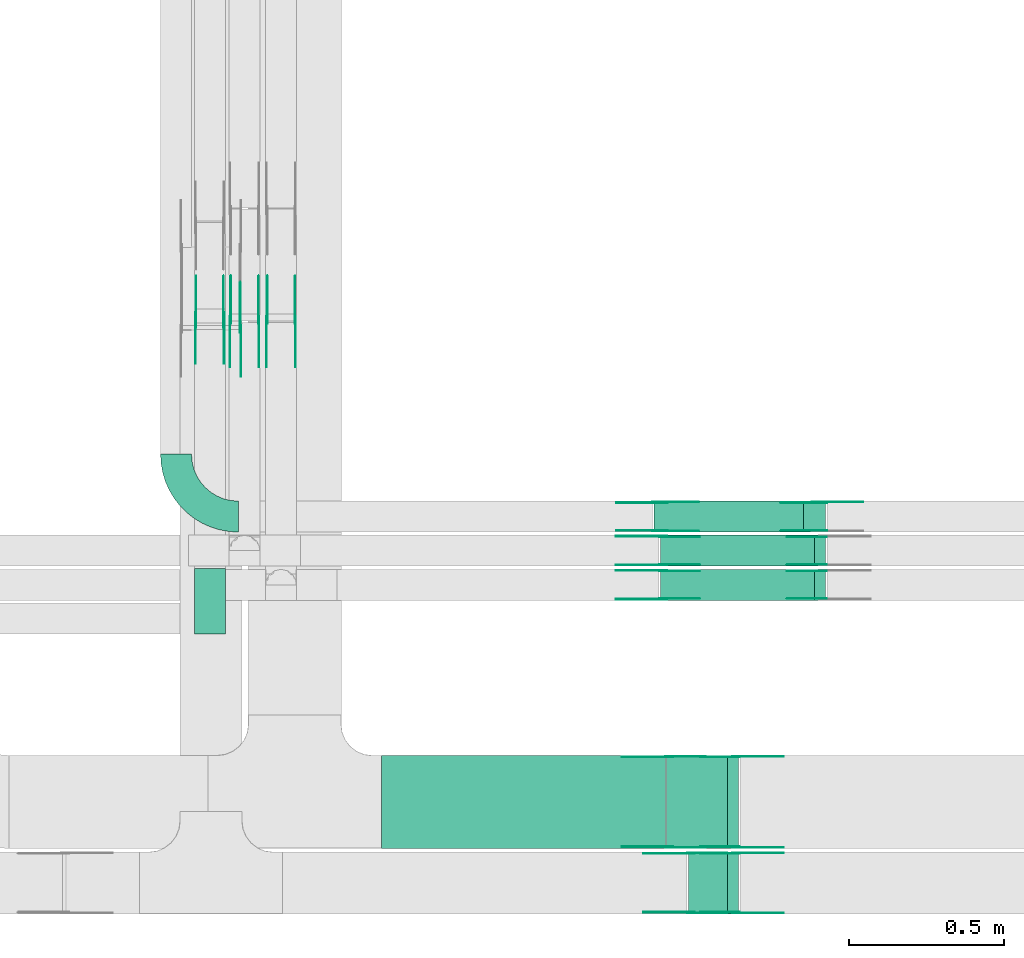
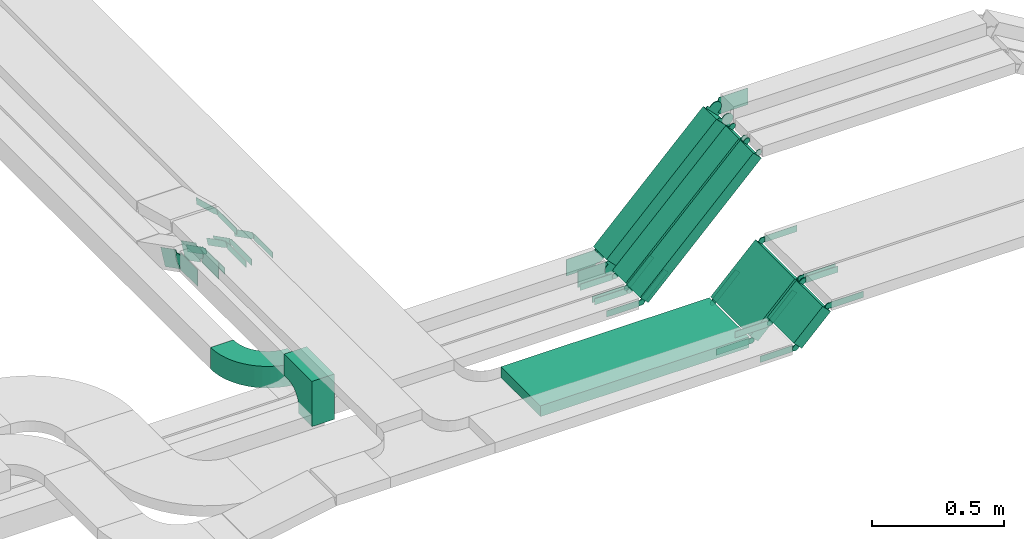
# One storey, part 16 of 19: 51 flow fittings, 6 flow segments.
"""IFC2X3 building model written with IfcOpenShell, lengths in millimetres."""

import ifcopenshell
import ifcopenshell.guid

model = None  # the IFC model being written
_history = None  # IfcOwnerHistory: only IFC2X3 demands one
_inside = {}  # id of a spatial element -> (the spatial element, [elements in it])
_under = {}  # id of a project, library or spatial element -> (it, [spatial elements below it])
_declared = {}  # id of a project -> (the project, [libraries it declares])
_typed = {}  # id of a type object -> (the type object, [elements of that type])
_made_of = {}  # id of a material, layer set ... -> (it, [elements and type objects made of it])


def new_model(schema):
    """Start an empty IFC model of exactly this schema.

    Asked for "IFC4X3", IfcOpenShell would pick the latest addendum, in which some entities
    have other attributes; the version numbers below select the first issue.
    IFC2X3 requires an IfcOwnerHistory on every rooted entity: one is made here for all.
    """
    global model, _history
    if schema == "IFC4X3":
        model = ifcopenshell.file(schema_version=(4, 3, 0, 0))
    else:
        model = ifcopenshell.file(schema=schema)
    _inside.clear()
    _under.clear()
    _declared.clear()
    _typed.clear()
    _made_of.clear()
    _history = None
    if model.schema == "IFC2X3":
        org = make("IfcOrganization", Name="unknown")
        user = make(
            "IfcPersonAndOrganization",
            ThePerson=make("IfcPerson", FamilyName="unknown"),
            TheOrganization=org,
        )
        app = make(
            "IfcApplication",
            ApplicationDeveloper=org,
            Version="unknown",
            ApplicationFullName="unknown",
            ApplicationIdentifier="unknown",
        )
        _history = make(
            "IfcOwnerHistory",
            OwningUser=user,
            OwningApplication=app,
            ChangeAction="ADDED",
            CreationDate=0,
        )
    return model


def make(cls, **values):
    """One entity of the class cls with the attributes given. An attribute that is None is left unset."""
    return model.create_entity(
        cls, **{name: value for name, value in values.items() if value is not None}
    )


def entity(cls, *values):
    """Any entity or typed value of the class cls, its attributes in the order of the schema. None: left unset."""
    e = model.create_entity(cls)
    for i, value in enumerate(values):
        if value is not None:
            e[i] = value
    return e


def rooted(cls, **values):
    """An entity with a GlobalId (a new one), such as an element, a storey or a relation."""
    return make(cls, GlobalId=ifcopenshell.guid.new(), OwnerHistory=_history, **values)


def si_unit(unit_type, name, prefix=None):
    """IfcSIUnit, for example si_unit("LENGTHUNIT", "METRE", prefix="MILLI")."""
    return make("IfcSIUnit", UnitType=unit_type, Prefix=prefix, Name=name)


def converted_unit(unit_type, name, factor, base, dimensions=None, offset=None):
    """IfcConversionBasedUnit, such as the inch: factor (a typed value) times the base unit."""
    return make(
        "IfcConversionBasedUnit"
        if offset is None
        else "IfcConversionBasedUnitWithOffset",
        ConversionOffset=offset,
        Dimensions=None
        if dimensions is None
        else entity("IfcDimensionalExponents", *dimensions),
        UnitType=unit_type,
        Name=name,
        ConversionFactor=make(
            "IfcMeasureWithUnit", ValueComponent=factor, UnitComponent=base
        ),
    )


def derived_unit(unit_type, elements):
    """IfcDerivedUnit: a product of units, each with its exponent."""
    return make(
        "IfcDerivedUnit",
        Elements=[
            make("IfcDerivedUnitElement", Unit=unit, Exponent=power)
            for unit, power in elements
        ],
        UnitType=unit_type,
    )


def assignment(units):
    """IfcUnitAssignment: the units of a project."""
    return None if units is None else make("IfcUnitAssignment", Units=units)


def point(xyz):
    """IfcCartesianPoint."""
    return None if xyz is None else make("IfcCartesianPoint", Coordinates=xyz)


def direction(xyz):
    """IfcDirection."""
    return None if xyz is None else make("IfcDirection", DirectionRatios=xyz)


def frame(location, z_axis=None, x_axis=None):
    """IfcAxis2Placement3D, a coordinate frame: its origin and axes. An axis left out is left unset."""
    return make(
        "IfcAxis2Placement3D",
        Location=point(location),
        Axis=direction(z_axis),
        RefDirection=direction(x_axis),
    )


def frame_2d(location, x_axis=None):
    """IfcAxis2Placement2D, a coordinate frame in the plane: its origin and x axis."""
    return make(
        "IfcAxis2Placement2D", Location=point(location), RefDirection=direction(x_axis)
    )


def origin():
    """The frame at (0, 0, 0) with its axes left unset."""
    return frame((0.0, 0.0, 0.0))


def origin_2d_with_axis():
    """The frame at (0, 0) in the plane with the x axis (1, 0) written out."""
    return frame_2d((0.0, 0.0), x_axis=(1.0, 0.0))


def place(relative_to, where):
    """IfcLocalPlacement: puts the frame where relative to a parent placement (None: the world)."""
    return make(
        "IfcLocalPlacement", PlacementRelTo=relative_to, RelativePlacement=where
    )


def context(
    kind, dimensions, precision=None, world=None, true_north=None, identifier=None
):
    """IfcGeometricRepresentationContext, for example the 3D "Model" context."""
    return make(
        "IfcGeometricRepresentationContext",
        ContextIdentifier=identifier,
        ContextType=kind,
        CoordinateSpaceDimension=dimensions,
        Precision=precision,
        WorldCoordinateSystem=world,
        TrueNorth=true_north,
    )


def subcontext(parent, identifier, kind, view, scale=None):
    """IfcGeometricRepresentationSubContext, for example "Body" below "Model"."""
    return make(
        "IfcGeometricRepresentationSubContext",
        ContextIdentifier=identifier,
        ContextType=kind,
        ParentContext=parent,
        TargetScale=scale,
        TargetView=view,
    )


def project(units=None, contexts=None):
    """IfcProject with its units and contexts."""
    return rooted(
        "IfcProject",
        Name="project",
        RepresentationContexts=contexts,
        UnitsInContext=assignment(units),
    )


def spatial(cls, under=None, at=None, **own):
    """A site, building, storey or space (cls), placed at a placement, below another one or the project."""
    s = rooted(cls, ObjectPlacement=at, **own)
    if under is not None:
        _under.setdefault(under.id(), (under, []))[1].append(s)
    return s


def polyline(points):
    """IfcPolyline through the points."""
    return make("IfcPolyline", Points=[point(p) for p in points])


def circle_curve(where, radius):
    """IfcCircle in the frame where."""
    return make("IfcCircle", Position=where, Radius=radius)


def parameter(value):
    """IfcParameterValue: where a trimmed curve begins or ends, as a parameter of its basis curve."""
    return model.create_entity("IfcParameterValue", value)


def trimmed(basis, trim1, trim2, sense, master):
    """IfcTrimmedCurve: the piece of a basis curve between two trims."""
    return make(
        "IfcTrimmedCurve",
        BasisCurve=basis,
        Trim1=trim1,
        Trim2=trim2,
        SenseAgreement=sense,
        MasterRepresentation=master,
    )


def segment(curve, same_sense, transition):
    """IfcCompositeCurveSegment."""
    return make(
        "IfcCompositeCurveSegment",
        Transition=transition,
        SameSense=same_sense,
        ParentCurve=curve,
    )


def composite_curve(segments, self_intersect=None):
    """IfcCompositeCurve: segments joined end to end."""
    return make("IfcCompositeCurve", Segments=segments, SelfIntersect=self_intersect)


def profile(cls, at=None, kind="AREA", **sizes):
    """A parametric profile (cls). Its sizes go by their IFC names, for example OverallWidth=200.0."""
    return make(cls, ProfileType=kind, Position=at, **sizes)


def rectangle(**sizes):
    """IfcRectangleProfileDef."""
    return profile("IfcRectangleProfileDef", **sizes)


def outline(outer, holes=None, kind="AREA"):
    """IfcArbitraryClosedProfileDef: a profile drawn as a closed curve; with holes, ...WithVoids."""
    if holes is None:
        return make("IfcArbitraryClosedProfileDef", ProfileType=kind, OuterCurve=outer)
    return make(
        "IfcArbitraryProfileDefWithVoids",
        ProfileType=kind,
        OuterCurve=outer,
        InnerCurves=holes,
    )


def extrude(swept, where, along, depth):
    """IfcExtrudedAreaSolid: the profile swept, set in the frame where, extruded along a direction by depth."""
    return make(
        "IfcExtrudedAreaSolid",
        SweptArea=swept,
        Position=where,
        ExtrudedDirection=direction(along),
        Depth=depth,
    )


def shape(context_of_items, identifier, shape_type, items):
    """IfcShapeRepresentation: the items that make up one representation, for example the "Body"."""
    return make(
        "IfcShapeRepresentation",
        ContextOfItems=context_of_items,
        RepresentationIdentifier=identifier,
        RepresentationType=shape_type,
        Items=items,
    )


def source(mapping_origin, context_of_items, identifier, shape_type, items):
    """IfcRepresentationMap: a shape defined once, which mapped items show again and again."""
    return make(
        "IfcRepresentationMap",
        MappingOrigin=mapping_origin,
        MappedRepresentation=shape(context_of_items, identifier, shape_type, items),
    )


def transform(
    local_origin,
    x_axis=None,
    y_axis=None,
    z_axis=None,
    scale=None,
    scale2=None,
    scale3=None,
    uniform=True,
):
    """IfcCartesianTransformationOperator3D, or its non-uniform kind. x_axis, y_axis, z_axis: its Axis1, 2, 3."""
    if uniform:
        return make(
            "IfcCartesianTransformationOperator3D",
            Axis1=direction(x_axis),
            Axis2=direction(y_axis),
            LocalOrigin=point(local_origin),
            Scale=scale,
            Axis3=direction(z_axis),
        )
    return make(
        "IfcCartesianTransformationOperator3DnonUniform",
        Axis1=direction(x_axis),
        Axis2=direction(y_axis),
        LocalOrigin=point(local_origin),
        Scale=scale,
        Axis3=direction(z_axis),
        Scale2=scale2,
        Scale3=scale3,
    )


def mapped(mapping_source, mapping_target):
    """IfcMappedItem: shows the shape of a source again, moved by a transform."""
    return make(
        "IfcMappedItem", MappingSource=mapping_source, MappingTarget=mapping_target
    )


def material(Name=None, Category=None):
    """IfcMaterial."""
    return make("IfcMaterial", Name=Name, Category=Category)


def made_of(thing, what):
    """Note that an element or type object is made of a material, layer set ...; save() writes the relation."""
    if what is not None:
        _made_of.setdefault(what.id(), (what, []))[1].append(thing)
    return thing


def type_object(cls, material=None, **own):
    """A type object (cls), such as IfcWallType, which elements share."""
    return made_of(rooted(cls, **own), material)


def type_shapes(of_type, sources):
    """Give a type object the sources (RepresentationMaps) that its elements show as mapped items."""
    of_type.RepresentationMaps = sources


def element(
    cls,
    number,
    at=None,
    inside=None,
    cuts=None,
    type_object=None,
    material=None,
    context=None,
    identifier="Body",
    shape_type=None,
    held_by="IfcProductDefinitionShape",
    body=None,
    shapes=None,
    **own,
):
    """One element of the class cls, such as IfcWall. Its Tag is "e" and its number.

    at: its placement. inside: the storey or other place that contains it. cuts: it is an
    opening in that element (IfcRelVoidsElement). A single representation is given by context,
    identifier, shape_type and body (its items); several are given by shapes. held_by: the class
    of the entity that holds the representations. save() writes the other relations.
    """
    e = rooted(cls, Tag="e%d" % number, ObjectPlacement=at, **own)
    if body is not None:
        shapes = [shape(context, identifier, shape_type, body)]
    if shapes is not None:
        e.Representation = make(held_by, Representations=shapes)
    if inside is not None:
        _inside.setdefault(inside.id(), (inside, []))[1].append(e)
    if cuts is not None:
        rooted(
            "IfcRelVoidsElement", RelatingBuildingElement=cuts, RelatedOpeningElement=e
        )
    if type_object is not None:
        _typed.setdefault(type_object.id(), (type_object, []))[1].append(e)
    return made_of(e, material)


def aggregate(whole, parts):
    """IfcRelAggregates: a whole, such as a stair, and the parts it consists of."""
    return rooted("IfcRelAggregates", RelatingObject=whole, RelatedObjects=parts)


def save(model, path):
    """Write the relations noted so far, then the file.

    IfcRelAggregates (storeys below a building ...), IfcRelContainedInSpatialStructure (elements
    in a storey), IfcRelDefinesByType, IfcRelAssociatesMaterial and IfcRelDeclares: one each for
    every whole, place, type object, material and project.
    """
    for whole, parts in _under.values():
        aggregate(whole, parts)
    for where, things in _inside.values():
        rooted(
            "IfcRelContainedInSpatialStructure",
            RelatedElements=things,
            RelatingStructure=where,
        )
    for kind, things in _typed.values():
        rooted("IfcRelDefinesByType", RelatedObjects=things, RelatingType=kind)
    for what, things in _made_of.values():
        rooted("IfcRelAssociatesMaterial", RelatedObjects=things, RelatingMaterial=what)
    for by, libraries in _declared.values():
        rooted("IfcRelDeclares", RelatingContext=by, RelatedDefinitions=libraries)
    model.write(path)


model = new_model("IFC2X3")

# Units and contexts
model_context = context("Model", 3, precision=0.01, world=origin(), true_north=direction((6.12303176911189e-17, 1.0)))
body_context = subcontext(model_context, "Body", "Model", "MODEL_VIEW")
ifc_project = project(units=[si_unit("LENGTHUNIT", "METRE", prefix="MILLI"), si_unit("AREAUNIT", "SQUARE_METRE"), si_unit("VOLUMEUNIT", "CUBIC_METRE"), converted_unit("PLANEANGLEUNIT", "DEGREE", entity("IfcRatioMeasure", 0.0174532925199433), si_unit("PLANEANGLEUNIT", "RADIAN"), dimensions=[0, 0, 0, 0, 0, 0, 0]), si_unit("MASSUNIT", "GRAM", prefix="KILO"), derived_unit("MASSDENSITYUNIT", [(si_unit("MASSUNIT", "GRAM", prefix="KILO"), 1), (si_unit("LENGTHUNIT", "METRE"), -3)]), derived_unit("MOMENTOFINERTIAUNIT", [(si_unit("LENGTHUNIT", "METRE"), 4)]), si_unit("TIMEUNIT", "SECOND"), si_unit("FREQUENCYUNIT", "HERTZ"), si_unit("THERMODYNAMICTEMPERATUREUNIT", "DEGREE_CELSIUS"), derived_unit("THERMALTRANSMITTANCEUNIT", [(si_unit("MASSUNIT", "GRAM", prefix="KILO"), 1), (si_unit("THERMODYNAMICTEMPERATUREUNIT", "KELVIN"), -1), (si_unit("TIMEUNIT", "SECOND"), -3)]), derived_unit("VOLUMETRICFLOWRATEUNIT", [(si_unit("LENGTHUNIT", "METRE"), 3), (si_unit("TIMEUNIT", "SECOND"), -1)]), derived_unit("MASSFLOWRATEUNIT", [(si_unit("MASSUNIT", "GRAM", prefix="KILO"), 1), (si_unit("TIMEUNIT", "SECOND"), -1)]), derived_unit("ROTATIONALFREQUENCYUNIT", [(si_unit("TIMEUNIT", "SECOND"), -1)]), si_unit("ELECTRICCURRENTUNIT", "AMPERE"), si_unit("ELECTRICVOLTAGEUNIT", "VOLT"), si_unit("POWERUNIT", "WATT"), si_unit("FORCEUNIT", "NEWTON", prefix="KILO"), si_unit("ILLUMINANCEUNIT", "LUX"), si_unit("LUMINOUSFLUXUNIT", "LUMEN"), si_unit("LUMINOUSINTENSITYUNIT", "CANDELA"), derived_unit("USERDEFINED", [(si_unit("MASSUNIT", "GRAM", prefix="KILO"), -1), (si_unit("LENGTHUNIT", "METRE"), -2), (si_unit("TIMEUNIT", "SECOND"), 3), (si_unit("LUMINOUSFLUXUNIT", "LUMEN"), 1)]), derived_unit("LINEARVELOCITYUNIT", [(si_unit("LENGTHUNIT", "METRE"), 1), (si_unit("TIMEUNIT", "SECOND"), -1)]), si_unit("PRESSUREUNIT", "PASCAL"), derived_unit("USERDEFINED", [(si_unit("LENGTHUNIT", "METRE"), -2), (si_unit("MASSUNIT", "GRAM", prefix="KILO"), 1), (si_unit("TIMEUNIT", "SECOND"), -2)]), derived_unit("LINEARFORCEUNIT", [(si_unit("MASSUNIT", "GRAM", prefix="KILO"), 1), (si_unit("LENGTHUNIT", "METRE"), 1), (si_unit("TIMEUNIT", "SECOND"), -2), (si_unit("LENGTHUNIT", "METRE"), -1)]), derived_unit("PLANARFORCEUNIT", [(si_unit("MASSUNIT", "GRAM", prefix="KILO"), 1), (si_unit("LENGTHUNIT", "METRE"), 1), (si_unit("TIMEUNIT", "SECOND"), -2), (si_unit("LENGTHUNIT", "METRE"), -2)])], contexts=[model_context])

# Site, building, storey
site_placement = place(None, origin())
site = spatial("IfcSite", under=ifc_project, at=site_placement, CompositionType="ELEMENT")
building_placement = place(site_placement, origin())
building = spatial("IfcBuilding", under=site, at=building_placement, CompositionType="ELEMENT")
storey_placement = place(building_placement, frame((0.0, 0.0, 12000.0)))
storey = spatial("IfcBuildingStorey", under=building, at=storey_placement, CompositionType="ELEMENT", Elevation=12000.0)

# Flow segments
cable_carrier_segment_type = type_object("IfcCableCarrierSegmentType", PredefinedType="CABLETRAYSEGMENT")
flow_segment_1_placement = place(storey_placement, frame((61621.17, 9844.99, 2531.17)))
element("IfcFlowSegment", 1, at=flow_segment_1_placement, inside=storey, type_object=cable_carrier_segment_type, context=body_context, shape_type="SweptSolid", body=[
    extrude(rectangle(XDim=99.999999999999, YDim=99.9999999999989, at=frame_2d((0.0, 0.0), x_axis=(0.0, 1.0))), frame((35.36, 50.0, 35.36), z_axis=(0.707106781186526, 0.0, 0.707106781186569), x_axis=(0.0, 1.0, 0.0)), (0.0, 0.0, 1.0), 681.584919885831),
])
for number, where in (
    (2, (61641.88, 9734.99, 2516.52)),
    (3, (61641.88, 9624.99, 2516.52)),
):
    element("IfcFlowSegment", number, at=place(storey_placement, frame(where)), inside=storey, type_object=cable_carrier_segment_type, context=body_context, shape_type="SweptSolid", body=[
        extrude(rectangle(XDim=49.9999999999895, YDim=99.9999999999989, at=frame_2d((0.0, 0.0), x_axis=(0.0, 1.0))), frame((17.68, 50.0, 17.68), z_axis=(0.707106781186548, 0.0, 0.707106781186548), x_axis=(0.0, 1.0, 0.0)), (0.0, 0.0, 1.0), 702.295598004474),
    ])
flow_segment_2_placement = place(storey_placement, frame((60742.55, 8824.99, 2800.0)))
element("IfcFlowSegment", 4, at=flow_segment_2_placement, inside=storey, type_object=cable_carrier_segment_type, context=body_context, shape_type="SweptSolid", body=[
    extrude(rectangle(XDim=914.543199050556, YDim=299.999999999999, at=origin_2d_with_axis()), frame((457.27, 150.0, 0.0)), (0.0, 0.0, 1.0), 50.0000000000016),
])
flow_segment_3_placement = place(storey_placement, frame((61661.63, 8824.99, 2816.52)))
element("IfcFlowSegment", 5, at=flow_segment_3_placement, inside=storey, type_object=cable_carrier_segment_type, context=body_context, shape_type="SweptSolid", body=[
    extrude(rectangle(XDim=278.03152929262, YDim=50.000000000011, at=origin_2d_with_axis()), frame((115.98, 0.0, 115.98), z_axis=(0.0, 1.0, 0.0), x_axis=(0.70710678118652, 0.0, 0.707106781186575)), (0.0, 0.0, 1.0), 299.999999999999),
])
flow_segment_4_placement = place(storey_placement, frame((61731.63, 8613.82, 2886.52)))
element("IfcFlowSegment", 6, at=flow_segment_4_placement, inside=storey, type_object=cable_carrier_segment_type, context=body_context, shape_type="SweptSolid", body=[
    extrude(rectangle(XDim=179.030212681478, YDim=50.0000000000033, at=origin_2d_with_axis()), frame((80.97, 0.0, 80.97), z_axis=(0.0, 1.0, 0.0), x_axis=(0.707106781186414, 0.0, 0.707106781186681)), (0.0, 0.0, 1.0), 200.0),
])

# Flow fittings
ifc_material_1 = material()
cable_carrier_fitting_type_1 = type_object("IfcCableCarrierFittingType", Name="470_DKC_S5_CDV 90 external vertical angle:-", PredefinedType="NOTDEFINED", material=ifc_material_1)
shared_shape_1 = source(origin(), body_context, "Body", "SweptSolid", [
    extrude(outline(composite_curve([segment(polyline([(65.71, 14.29), (95.71, 14.29)]), True, "CONTINUOUS"), segment(polyline([(95.71, 14.29), (95.71, 114.29)]), True, "CONTINUOUS"), segment(polyline([(95.71, 114.29), (-114.29, 114.29)]), True, "CONTINUOUS"), segment(polyline([(-114.29, 114.29), (-114.29, -95.71)]), True, "CONTINUOUS"), segment(polyline([(-114.29, -95.71), (-14.29, -95.71)]), True, "CONTINUOUS"), segment(polyline([(-14.29, -95.71), (-14.29, -65.71)]), True, "CONTINUOUS"), segment(trimmed(circle_curve(frame_2d((65.71, -65.71), x_axis=(-1.0, 0.0)), 80.0), [parameter(270.0)], [parameter(2.54444374517082e-13)], True, "PARAMETER"), False, "CONTINUOUS")], self_intersect=False)), frame((-64.29, 64.29, -49.0), z_axis=(0.0, 0.0, 1.0), x_axis=(-1.0, 0.0, 0.0)), (0.0, 0.0, 1.0), 99.0000000000002),
])
type_shapes(cable_carrier_fitting_type_1, [shared_shape_1])
flow_fitting_1_placement = place(storey_placement, frame((60188.97, 9567.13, 2705.0), z_axis=(1.0, 0.0, 0.0), x_axis=(0.0, -1.0, 0.0)))
element("IfcFlowFitting", 7, at=flow_fitting_1_placement, inside=storey, type_object=cable_carrier_fitting_type_1, material=ifc_material_1, Name="470_DKC_S5_90 external vertical angle", ObjectType="470_DKC_S5_CDV 90 external vertical angle:-", context=body_context, shape_type="MappedRepresentation", body=[
    mapped(shared_shape_1, transform((0.0, 0.0, 0.0), scale=1.0)),
])
ifc_material_2 = material(Name="G")
cable_carrier_fitting_type_2 = type_object("IfcCableCarrierFittingType", PredefinedType="NOTDEFINED", material=ifc_material_2)
shared_shape_2 = source(origin(), body_context, "Body", "SweptSolid", [
    extrude(outline(composite_curve([segment(trimmed(circle_curve(frame_2d((-44.59, 0.0), x_axis=(1.0, 0.0)), 12.5), [parameter(90.0000000000007)], [parameter(270.0)], True, "PARAMETER"), True, "CONTINUOUS"), segment(polyline([(-44.59, -12.5), (-33.09, -12.5)]), True, "CONTINUOUS"), segment(polyline([(-33.09, -12.5), (-31.23, -14.5)]), True, "CONTINUOUS"), segment(polyline([(-31.23, -14.5), (108.91, -14.5)]), True, "CONTINUOUS"), segment(polyline([(108.91, -14.5), (108.91, 14.5)]), True, "CONTINUOUS"), segment(polyline([(108.91, 14.5), (-31.23, 14.5)]), True, "CONTINUOUS"), segment(polyline([(-31.23, 14.5), (-33.09, 12.5)]), True, "CONTINUOUS"), segment(polyline([(-33.09, 12.5), (-44.59, 12.5)]), True, "CONTINUOUS")], self_intersect=False)), frame((44.59, 0.0, 0.0), z_axis=(0.0, 0.0, -1.0), x_axis=(1.0, 0.0, 0.0)), (0.0, 0.0, -1.0), 2.0),
])
type_shapes(cable_carrier_fitting_type_2, [shared_shape_2])
for number, where, z_axis, x_axis in (
    (8, (60288.01, 10499.75, 2895.0), (1.0, 0.0, 0.0), (0.0, -1.0, 0.0)),
    (9, (61650.35, 9830.45, 2525.0), (0.0, 1.0, 0.0), (-1.0, 0.0, 0.0)),
):
    element("IfcFlowFitting", number, at=place(storey_placement, frame(where, z_axis=z_axis, x_axis=x_axis)), inside=storey, type_object=cable_carrier_fitting_type_2, material=ifc_material_2, context=body_context, shape_type="MappedRepresentation", body=[
        mapped(shared_shape_2, transform((0.0, 0.0, 0.0), scale=1.0)),
    ])
cable_carrier_fitting_type_3 = type_object("IfcCableCarrierFittingType", PredefinedType="NOTDEFINED", material=ifc_material_2)
type_shapes(cable_carrier_fitting_type_3, [shared_shape_2])
flow_fitting_2_placement = place(storey_placement, frame((61650.35, 9741.53, 2525.0), z_axis=(0.0, -1.0, 0.0), x_axis=(0.707106781186565, 0.0, 0.70710678118653)))
element("IfcFlowFitting", 10, at=flow_fitting_2_placement, inside=storey, type_object=cable_carrier_fitting_type_3, material=ifc_material_2, context=body_context, shape_type="MappedRepresentation", body=[
    mapped(shared_shape_2, transform((0.0, 0.0, 0.0), scale=1.0)),
])
flow_fitting_3_placement = place(storey_placement, frame((61650.35, 9720.45, 2525.0), z_axis=(0.0, 1.0, 0.0), x_axis=(-1.0, 0.0, 0.0)))
element("IfcFlowFitting", 11, at=flow_fitting_3_placement, inside=storey, type_object=cable_carrier_fitting_type_2, material=ifc_material_2, context=body_context, shape_type="MappedRepresentation", body=[
    mapped(shared_shape_2, transform((0.0, 0.0, 0.0), scale=1.0)),
])
flow_fitting_4_placement = place(storey_placement, frame((61650.35, 9631.53, 2525.0), z_axis=(0.0, -1.0, 0.0), x_axis=(0.70710678118656, 0.0, 0.707106781186535)))
element("IfcFlowFitting", 12, at=flow_fitting_4_placement, inside=storey, type_object=cable_carrier_fitting_type_3, material=ifc_material_2, context=body_context, shape_type="MappedRepresentation", body=[
    mapped(shared_shape_2, transform((0.0, 0.0, 0.0), scale=1.0)),
])
flow_fitting_5_placement = place(storey_placement, frame((61670.11, 8829.53, 2825.0), z_axis=(0.0, -1.0, 0.0), x_axis=(0.707106781186591, 0.0, 0.707106781186504)))
element("IfcFlowFitting", 13, at=flow_fitting_5_placement, inside=storey, type_object=cable_carrier_fitting_type_2, material=ifc_material_2, context=body_context, shape_type="MappedRepresentation", body=[
    mapped(shared_shape_2, transform((0.0, 0.0, 0.0), scale=1.0)),
])
flow_fitting_6_placement = place(storey_placement, frame((61670.11, 9118.45, 2825.0), z_axis=(0.0, 1.0, 0.0), x_axis=(-1.0, 0.0, 0.0)))
element("IfcFlowFitting", 14, at=flow_fitting_6_placement, inside=storey, type_object=cable_carrier_fitting_type_3, material=ifc_material_2, context=body_context, shape_type="MappedRepresentation", body=[
    mapped(shared_shape_2, transform((0.0, 0.0, 0.0), scale=1.0)),
])
flow_fitting_7_placement = place(storey_placement, frame((61740.11, 8618.36, 2895.0), z_axis=(0.0, -1.0, 0.0), x_axis=(0.707106781186497, 0.0, 0.707106781186598)))
element("IfcFlowFitting", 15, at=flow_fitting_7_placement, inside=storey, type_object=cable_carrier_fitting_type_2, material=ifc_material_2, context=body_context, shape_type="MappedRepresentation", body=[
    mapped(shared_shape_2, transform((0.0, 0.0, 0.0), scale=1.0)),
])
for number, where, z_axis, x_axis in (
    (16, (61740.11, 8807.28, 2895.0), (0.0, 1.0, 0.0), (-1.0, 0.0, 0.0)),
    (17, (62165.35, 9741.53, 3040.0), (0.0, -1.0, 0.0), (-0.70710678118656, 0.0, -0.707106781186535)),
):
    element("IfcFlowFitting", number, at=place(storey_placement, frame(where, z_axis=z_axis, x_axis=x_axis)), inside=storey, type_object=cable_carrier_fitting_type_3, material=ifc_material_2, context=body_context, shape_type="MappedRepresentation", body=[
        mapped(shared_shape_2, transform((0.0, 0.0, 0.0), scale=1.0)),
    ])
flow_fitting_8_placement = place(storey_placement, frame((61885.11, 9120.45, 3040.0), z_axis=(0.0, 1.0, 0.0), x_axis=(1.0, 0.0, 0.0)))
element("IfcFlowFitting", 18, at=flow_fitting_8_placement, inside=storey, type_object=cable_carrier_fitting_type_2, material=ifc_material_2, context=body_context, shape_type="MappedRepresentation", body=[
    mapped(shared_shape_2, transform((0.0, 0.0, 0.0), scale=1.0)),
])
flow_fitting_9_placement = place(storey_placement, frame((61885.11, 8831.53, 3040.0), z_axis=(0.0, -1.0, 0.0), x_axis=(-0.707106781186608, 0.0, -0.707106781186487)))
element("IfcFlowFitting", 19, at=flow_fitting_9_placement, inside=storey, type_object=cable_carrier_fitting_type_3, material=ifc_material_2, context=body_context, shape_type="MappedRepresentation", body=[
    mapped(shared_shape_2, transform((0.0, 0.0, 0.0), scale=1.0)),
])
flow_fitting_10_placement = place(storey_placement, frame((61885.1, 8809.28, 3040.0), z_axis=(0.0, 1.0, 0.0), x_axis=(1.0, 0.0, 0.0)))
element("IfcFlowFitting", 20, at=flow_fitting_10_placement, inside=storey, type_object=cable_carrier_fitting_type_2, material=ifc_material_2, context=body_context, shape_type="MappedRepresentation", body=[
    mapped(shared_shape_2, transform((0.0, 0.0, 0.0), scale=1.0)),
])
for number, where, z_axis, x_axis in (
    (21, (61885.1, 8620.36, 3040.0), (0.0, -1.0, 0.0), (-0.707106781186586, 0.0, -0.707106781186509)),
    (22, (62165.35, 9631.53, 3040.0), (0.0, -1.0, 0.0), (-0.70710678118656, 0.0, -0.707106781186535)),
):
    element("IfcFlowFitting", number, at=place(storey_placement, frame(where, z_axis=z_axis, x_axis=x_axis)), inside=storey, type_object=cable_carrier_fitting_type_3, material=ifc_material_2, context=body_context, shape_type="MappedRepresentation", body=[
        mapped(shared_shape_2, transform((0.0, 0.0, 0.0), scale=1.0)),
    ])
flow_fitting_11_placement = place(storey_placement, frame((60463.81, 10529.12, 2705.0), z_axis=(1.0, 0.0, 0.0), x_axis=(0.0, -1.0, 0.0)))
element("IfcFlowFitting", 23, at=flow_fitting_11_placement, inside=storey, type_object=cable_carrier_fitting_type_2, material=ifc_material_2, context=body_context, shape_type="MappedRepresentation", body=[
    mapped(shared_shape_2, transform((0.0, 0.0, 0.0), scale=1.0)),
])
flow_fitting_12_placement = place(storey_placement, frame((60374.89, 10529.12, 2705.0), z_axis=(-1.0, 0.0, 0.0), x_axis=(0.0, 0.891006524188382, -0.453990499739519)))
element("IfcFlowFitting", 24, at=flow_fitting_12_placement, inside=storey, type_object=cable_carrier_fitting_type_3, material=ifc_material_2, context=body_context, shape_type="MappedRepresentation", body=[
    mapped(shared_shape_2, transform((0.0, 0.0, 0.0), scale=1.0)),
])
flow_fitting_13_placement = place(storey_placement, frame((60346.24, 10529.12, 2705.0), z_axis=(1.0, 0.0, 0.0), x_axis=(0.0, -1.0, 0.0)))
element("IfcFlowFitting", 25, at=flow_fitting_13_placement, inside=storey, type_object=cable_carrier_fitting_type_2, material=ifc_material_2, context=body_context, shape_type="MappedRepresentation", body=[
    mapped(shared_shape_2, transform((0.0, 0.0, 0.0), scale=1.0)),
])
flow_fitting_14_placement = place(storey_placement, frame((60257.32, 10529.12, 2705.0), z_axis=(-1.0, 0.0, 0.0), x_axis=(0.0, 0.891006524188381, -0.453990499739522)))
element("IfcFlowFitting", 26, at=flow_fitting_14_placement, inside=storey, type_object=cable_carrier_fitting_type_3, material=ifc_material_2, context=body_context, shape_type="MappedRepresentation", body=[
    mapped(shared_shape_2, transform((0.0, 0.0, 0.0), scale=1.0)),
])
cable_carrier_fitting_type_4 = type_object("IfcCableCarrierFittingType", PredefinedType="NOTDEFINED", material=ifc_material_2)
shared_shape_3 = source(origin(), body_context, "Body", "SweptSolid", [
    extrude(outline(composite_curve([segment(trimmed(circle_curve(frame_2d((-44.59, 0.0), x_axis=(1.0, 0.0)), 12.5), [parameter(90.0000000000007)], [parameter(270.0)], True, "PARAMETER"), True, "CONTINUOUS"), segment(polyline([(-44.59, -12.5), (-33.09, -12.5)]), True, "CONTINUOUS"), segment(polyline([(-33.09, -12.5), (-31.23, -14.5)]), True, "CONTINUOUS"), segment(polyline([(-31.23, -14.5), (108.91, -14.5)]), True, "CONTINUOUS"), segment(polyline([(108.91, -14.5), (108.91, 14.5)]), True, "CONTINUOUS"), segment(polyline([(108.91, 14.5), (-31.23, 14.5)]), True, "CONTINUOUS"), segment(polyline([(-31.23, 14.5), (-33.09, 12.5)]), True, "CONTINUOUS"), segment(polyline([(-33.09, 12.5), (-44.59, 12.5)]), True, "CONTINUOUS")], self_intersect=False)), frame((44.59, 0.0, 0.0)), (0.0, 0.0, 1.0), 2.0),
])
type_shapes(cable_carrier_fitting_type_4, [shared_shape_3])
flow_fitting_15_placement = place(storey_placement, frame((60286.01, 10499.75, 2895.0), z_axis=(1.0, 0.0, 0.0), x_axis=(0.0, 0.965925826289068, -0.258819045102521)))
element("IfcFlowFitting", 27, at=flow_fitting_15_placement, inside=storey, type_object=cable_carrier_fitting_type_4, material=ifc_material_2, context=body_context, shape_type="MappedRepresentation", body=[
    mapped(shared_shape_3, transform((0.0, 0.0, 0.0), scale=1.0)),
])
cable_carrier_fitting_type_5 = type_object("IfcCableCarrierFittingType", PredefinedType="NOTDEFINED", material=ifc_material_2)
type_shapes(cable_carrier_fitting_type_5, [shared_shape_3])
flow_fitting_16_placement = place(storey_placement, frame((61650.35, 9739.53, 2525.0), z_axis=(0.0, -1.0, 0.0), x_axis=(-1.0, 0.0, 0.0)))
element("IfcFlowFitting", 28, at=flow_fitting_16_placement, inside=storey, type_object=cable_carrier_fitting_type_5, material=ifc_material_2, context=body_context, shape_type="MappedRepresentation", body=[
    mapped(shared_shape_3, transform((0.0, 0.0, 0.0), scale=1.0)),
])
flow_fitting_17_placement = place(storey_placement, frame((61650.35, 9828.45, 2525.0), z_axis=(0.0, 1.0, 0.0), x_axis=(0.707106781186565, 0.0, 0.70710678118653)))
element("IfcFlowFitting", 29, at=flow_fitting_17_placement, inside=storey, type_object=cable_carrier_fitting_type_4, material=ifc_material_2, context=body_context, shape_type="MappedRepresentation", body=[
    mapped(shared_shape_3, transform((0.0, 0.0, 0.0), scale=1.0)),
])
flow_fitting_18_placement = place(storey_placement, frame((61650.35, 9629.53, 2525.0), z_axis=(0.0, -1.0, 0.0), x_axis=(-1.0, 0.0, 0.0)))
element("IfcFlowFitting", 30, at=flow_fitting_18_placement, inside=storey, type_object=cable_carrier_fitting_type_5, material=ifc_material_2, context=body_context, shape_type="MappedRepresentation", body=[
    mapped(shared_shape_3, transform((0.0, 0.0, 0.0), scale=1.0)),
])
flow_fitting_19_placement = place(storey_placement, frame((61650.35, 9718.45, 2525.0), z_axis=(0.0, 1.0, 0.0), x_axis=(0.70710678118656, 0.0, 0.707106781186535)))
element("IfcFlowFitting", 31, at=flow_fitting_19_placement, inside=storey, type_object=cable_carrier_fitting_type_4, material=ifc_material_2, context=body_context, shape_type="MappedRepresentation", body=[
    mapped(shared_shape_3, transform((0.0, 0.0, 0.0), scale=1.0)),
])
flow_fitting_20_placement = place(storey_placement, frame((61670.11, 9120.45, 2825.0), z_axis=(0.0, 1.0, 0.0), x_axis=(0.707106781186591, 0.0, 0.707106781186504)))
element("IfcFlowFitting", 32, at=flow_fitting_20_placement, inside=storey, type_object=cable_carrier_fitting_type_5, material=ifc_material_2, context=body_context, shape_type="MappedRepresentation", body=[
    mapped(shared_shape_3, transform((0.0, 0.0, 0.0), scale=1.0)),
])
flow_fitting_21_placement = place(storey_placement, frame((61670.11, 8831.53, 2825.0), z_axis=(0.0, -1.0, 0.0), x_axis=(-1.0, 0.0, 0.0)))
element("IfcFlowFitting", 33, at=flow_fitting_21_placement, inside=storey, type_object=cable_carrier_fitting_type_4, material=ifc_material_2, context=body_context, shape_type="MappedRepresentation", body=[
    mapped(shared_shape_3, transform((0.0, 0.0, 0.0), scale=1.0)),
])
flow_fitting_22_placement = place(storey_placement, frame((61740.11, 8809.28, 2895.0), z_axis=(0.0, 1.0, 0.0), x_axis=(0.707106781186497, 0.0, 0.707106781186598)))
element("IfcFlowFitting", 34, at=flow_fitting_22_placement, inside=storey, type_object=cable_carrier_fitting_type_5, material=ifc_material_2, context=body_context, shape_type="MappedRepresentation", body=[
    mapped(shared_shape_3, transform((0.0, 0.0, 0.0), scale=1.0)),
])
for number, where, z_axis, x_axis in (
    (35, (61740.11, 8620.36, 2895.0), (0.0, -1.0, 0.0), (-1.0, 0.0, 0.0)),
    (36, (62165.35, 9828.45, 3040.0), (0.0, 1.0, 0.0), (-0.70710678118656, 0.0, -0.707106781186535)),
):
    element("IfcFlowFitting", number, at=place(storey_placement, frame(where, z_axis=z_axis, x_axis=x_axis)), inside=storey, type_object=cable_carrier_fitting_type_4, material=ifc_material_2, context=body_context, shape_type="MappedRepresentation", body=[
        mapped(shared_shape_3, transform((0.0, 0.0, 0.0), scale=1.0)),
    ])
flow_fitting_23_placement = place(storey_placement, frame((61885.11, 8829.53, 3040.0), z_axis=(0.0, -1.0, 0.0), x_axis=(1.0, 0.0, 0.0)))
element("IfcFlowFitting", 37, at=flow_fitting_23_placement, inside=storey, type_object=cable_carrier_fitting_type_5, material=ifc_material_2, context=body_context, shape_type="MappedRepresentation", body=[
    mapped(shared_shape_3, transform((0.0, 0.0, 0.0), scale=1.0)),
])
flow_fitting_24_placement = place(storey_placement, frame((61885.11, 9118.45, 3040.0), z_axis=(0.0, 1.0, 0.0), x_axis=(-0.707106781186608, 0.0, -0.707106781186487)))
element("IfcFlowFitting", 38, at=flow_fitting_24_placement, inside=storey, type_object=cable_carrier_fitting_type_4, material=ifc_material_2, context=body_context, shape_type="MappedRepresentation", body=[
    mapped(shared_shape_3, transform((0.0, 0.0, 0.0), scale=1.0)),
])
flow_fitting_25_placement = place(storey_placement, frame((61885.1, 8618.36, 3040.0), z_axis=(0.0, -1.0, 0.0), x_axis=(1.0, 0.0, 0.0)))
element("IfcFlowFitting", 39, at=flow_fitting_25_placement, inside=storey, type_object=cable_carrier_fitting_type_5, material=ifc_material_2, context=body_context, shape_type="MappedRepresentation", body=[
    mapped(shared_shape_3, transform((0.0, 0.0, 0.0), scale=1.0)),
])
for number, where, z_axis, x_axis in (
    (40, (61885.1, 8807.28, 3040.0), (0.0, 1.0, 0.0), (-0.707106781186586, 0.0, -0.707106781186509)),
    (41, (62165.35, 9718.45, 3040.0), (0.0, 1.0, 0.0), (-0.70710678118656, 0.0, -0.707106781186535)),
):
    element("IfcFlowFitting", number, at=place(storey_placement, frame(where, z_axis=z_axis, x_axis=x_axis)), inside=storey, type_object=cable_carrier_fitting_type_4, material=ifc_material_2, context=body_context, shape_type="MappedRepresentation", body=[
        mapped(shared_shape_3, transform((0.0, 0.0, 0.0), scale=1.0)),
    ])
flow_fitting_26_placement = place(storey_placement, frame((60372.89, 10529.12, 2705.0), z_axis=(-1.0, 0.0, 0.0), x_axis=(0.0, -1.0, 0.0)))
element("IfcFlowFitting", 42, at=flow_fitting_26_placement, inside=storey, type_object=cable_carrier_fitting_type_5, material=ifc_material_2, context=body_context, shape_type="MappedRepresentation", body=[
    mapped(shared_shape_3, transform((0.0, 0.0, 0.0), scale=1.0)),
])
flow_fitting_27_placement = place(storey_placement, frame((60461.81, 10529.12, 2705.0), z_axis=(1.0, 0.0, 0.0), x_axis=(0.0, 0.891006524188382, -0.453990499739519)))
element("IfcFlowFitting", 43, at=flow_fitting_27_placement, inside=storey, type_object=cable_carrier_fitting_type_4, material=ifc_material_2, context=body_context, shape_type="MappedRepresentation", body=[
    mapped(shared_shape_3, transform((0.0, 0.0, 0.0), scale=1.0)),
])
flow_fitting_28_placement = place(storey_placement, frame((60255.32, 10529.12, 2705.0), z_axis=(-1.0, 0.0, 0.0), x_axis=(0.0, -1.0, 0.0)))
element("IfcFlowFitting", 44, at=flow_fitting_28_placement, inside=storey, type_object=cable_carrier_fitting_type_5, material=ifc_material_2, context=body_context, shape_type="MappedRepresentation", body=[
    mapped(shared_shape_3, transform((0.0, 0.0, 0.0), scale=1.0)),
])
flow_fitting_29_placement = place(storey_placement, frame((60344.24, 10529.12, 2705.0), z_axis=(1.0, 0.0, 0.0), x_axis=(0.0, 0.891006524188381, -0.453990499739522)))
element("IfcFlowFitting", 45, at=flow_fitting_29_placement, inside=storey, type_object=cable_carrier_fitting_type_4, material=ifc_material_2, context=body_context, shape_type="MappedRepresentation", body=[
    mapped(shared_shape_3, transform((0.0, 0.0, 0.0), scale=1.0)),
])
cable_carrier_fitting_type_6 = type_object("IfcCableCarrierFittingType", Name="470_DKC_S5_Variable Angle Elbow 0-45:-", PredefinedType="NOTDEFINED", material=ifc_material_1)
shared_shape_4 = source(origin(), body_context, "Body", "SweptSolid", [
    extrude(outline(composite_curve([segment(polyline([(-100.75, -150.25), (-99.75, -150.25)]), True, "CONTINUOUS"), segment(trimmed(circle_curve(frame_2d((-99.75, 99.75), x_axis=(0.0, -1.0)), 250.0), [parameter(0.0)], [parameter(90.0000000000001)], True, "PARAMETER"), True, "CONTINUOUS"), segment(polyline([(150.25, 99.75), (150.25, 100.75)]), True, "CONTINUOUS"), segment(polyline([(150.25, 100.75), (50.25, 100.75)]), True, "CONTINUOUS"), segment(polyline([(50.25, 100.75), (50.25, 99.75)]), True, "CONTINUOUS"), segment(trimmed(circle_curve(frame_2d((-99.75, 99.75), x_axis=(0.0, -1.0)), 150.0), [parameter(0.0)], [parameter(90.0000000000001)], True, "PARAMETER"), False, "CONTINUOUS"), segment(polyline([(-99.75, -50.25), (-100.75, -50.25)]), True, "CONTINUOUS"), segment(polyline([(-100.75, -50.25), (-100.75, -150.25)]), True, "CONTINUOUS")], self_intersect=False)), frame((-100.25, 100.25, -50.0)), (0.0, 0.0, 1.0), 100.0),
])
type_shapes(cable_carrier_fitting_type_6, [shared_shape_4])
flow_fitting_30_placement = place(storey_placement, frame((60080.0, 9894.99, 2550.0), z_axis=(0.0, 0.0, 1.0), x_axis=(0.0, -1.0, 0.0)))
element("IfcFlowFitting", 46, at=flow_fitting_30_placement, inside=storey, type_object=cable_carrier_fitting_type_6, material=ifc_material_1, Name="470_DKC_S5_Variable Angle Elbow 0-45:-", ObjectType="470_DKC_S5_Variable Angle Elbow 0-45:-", context=body_context, shape_type="MappedRepresentation", body=[
    mapped(shared_shape_4, transform((0.0, 0.0, 0.0), scale=1.0)),
])
cable_carrier_fitting_type_7 = type_object("IfcCableCarrierFittingType", PredefinedType="NOTDEFINED", material=ifc_material_2)
shared_shape_5 = source(origin(), body_context, "Body", "SweptSolid", [
    extrude(outline(composite_curve([segment(trimmed(circle_curve(frame_2d((-41.47, 0.0), x_axis=(1.0, 0.0)), 25.0), [parameter(90.0000000000007)], [parameter(270.0)], True, "PARAMETER"), True, "CONTINUOUS"), segment(polyline([(-41.47, -25.0), (-29.97, -25.0)]), True, "CONTINUOUS"), segment(polyline([(-29.97, -25.0), (-28.1, -38.5)]), True, "CONTINUOUS"), segment(polyline([(-28.1, -38.5), (99.53, -38.5)]), True, "CONTINUOUS"), segment(polyline([(99.53, -38.5), (99.53, 38.5)]), True, "CONTINUOUS"), segment(polyline([(99.53, 38.5), (-28.1, 38.5)]), True, "CONTINUOUS"), segment(polyline([(-28.1, 38.5), (-29.97, 25.0)]), True, "CONTINUOUS"), segment(polyline([(-29.97, 25.0), (-41.47, 25.0)]), True, "CONTINUOUS")], self_intersect=False)), frame((41.47, 0.0, 0.0), z_axis=(0.0, 0.0, -1.0), x_axis=(1.0, 0.0, 0.0)), (0.0, 0.0, -1.0), 2.0),
])
type_shapes(cable_carrier_fitting_type_7, [shared_shape_5])
flow_fitting_31_placement = place(storey_placement, frame((60234.43, 10529.12, 2705.0), z_axis=(1.0, 0.0, 0.0), x_axis=(0.0, -1.0, 0.0)))
element("IfcFlowFitting", 47, at=flow_fitting_31_placement, inside=storey, type_object=cable_carrier_fitting_type_7, material=ifc_material_2, context=body_context, shape_type="MappedRepresentation", body=[
    mapped(shared_shape_5, transform((0.0, 0.0, 0.0), scale=1.0)),
])
cable_carrier_fitting_type_8 = type_object("IfcCableCarrierFittingType", PredefinedType="NOTDEFINED", material=ifc_material_2)
type_shapes(cable_carrier_fitting_type_8, [shared_shape_5])
flow_fitting_32_placement = place(storey_placement, frame((60145.51, 10529.12, 2705.0), z_axis=(-1.0, 0.0, 0.0), x_axis=(0.0, 0.891006524188381, -0.453990499739522)))
element("IfcFlowFitting", 48, at=flow_fitting_32_placement, inside=storey, type_object=cable_carrier_fitting_type_8, material=ifc_material_2, context=body_context, shape_type="MappedRepresentation", body=[
    mapped(shared_shape_5, transform((0.0, 0.0, 0.0), scale=1.0)),
])
flow_fitting_33_placement = place(storey_placement, frame((61640.0, 9849.53, 2550.0), z_axis=(0.0, -1.0, 0.0), x_axis=(0.707106781186429, 0.0, 0.707106781186666)))
element("IfcFlowFitting", 49, at=flow_fitting_33_placement, inside=storey, type_object=cable_carrier_fitting_type_7, material=ifc_material_2, context=body_context, shape_type="MappedRepresentation", body=[
    mapped(shared_shape_5, transform((0.0, 0.0, 0.0), scale=1.0)),
])
flow_fitting_34_placement = place(storey_placement, frame((61640.0, 9938.45, 2550.0), z_axis=(0.0, 1.0, 0.0), x_axis=(-1.0, 0.0, 0.0)))
element("IfcFlowFitting", 50, at=flow_fitting_34_placement, inside=storey, type_object=cable_carrier_fitting_type_8, material=ifc_material_2, context=body_context, shape_type="MappedRepresentation", body=[
    mapped(shared_shape_5, transform((0.0, 0.0, 0.0), scale=1.0)),
])
flow_fitting_35_placement = place(storey_placement, frame((62155.0, 9940.45, 3065.0), z_axis=(0.0, 1.0, 0.0), x_axis=(1.0, 0.0, 0.0)))
element("IfcFlowFitting", 51, at=flow_fitting_35_placement, inside=storey, type_object=cable_carrier_fitting_type_7, material=ifc_material_2, context=body_context, shape_type="MappedRepresentation", body=[
    mapped(shared_shape_5, transform((0.0, 0.0, 0.0), scale=1.0)),
])
flow_fitting_36_placement = place(storey_placement, frame((62155.0, 9851.53, 3065.0), z_axis=(0.0, -1.0, 0.0), x_axis=(-0.70710678118654, 0.0, -0.707106781186555)))
element("IfcFlowFitting", 52, at=flow_fitting_36_placement, inside=storey, type_object=cable_carrier_fitting_type_8, material=ifc_material_2, context=body_context, shape_type="MappedRepresentation", body=[
    mapped(shared_shape_5, transform((0.0, 0.0, 0.0), scale=1.0)),
])
cable_carrier_fitting_type_9 = type_object("IfcCableCarrierFittingType", PredefinedType="NOTDEFINED", material=ifc_material_2)
shared_shape_6 = source(origin(), body_context, "Body", "SweptSolid", [
    extrude(outline(composite_curve([segment(trimmed(circle_curve(frame_2d((-41.47, 0.0), x_axis=(1.0, 0.0)), 25.0), [parameter(90.0000000000007)], [parameter(270.0)], True, "PARAMETER"), True, "CONTINUOUS"), segment(polyline([(-41.47, -25.0), (-29.97, -25.0)]), True, "CONTINUOUS"), segment(polyline([(-29.97, -25.0), (-28.1, -38.5)]), True, "CONTINUOUS"), segment(polyline([(-28.1, -38.5), (99.53, -38.5)]), True, "CONTINUOUS"), segment(polyline([(99.53, -38.5), (99.53, 38.5)]), True, "CONTINUOUS"), segment(polyline([(99.53, 38.5), (-28.1, 38.5)]), True, "CONTINUOUS"), segment(polyline([(-28.1, 38.5), (-29.97, 25.0)]), True, "CONTINUOUS"), segment(polyline([(-29.97, 25.0), (-41.47, 25.0)]), True, "CONTINUOUS")], self_intersect=False)), frame((41.47, 0.0, 0.0)), (0.0, 0.0, 1.0), 2.0),
])
type_shapes(cable_carrier_fitting_type_9, [shared_shape_6])
flow_fitting_37_placement = place(storey_placement, frame((60143.51, 10529.12, 2705.0), z_axis=(-1.0, 0.0, 0.0), x_axis=(0.0, -1.0, 0.0)))
element("IfcFlowFitting", 53, at=flow_fitting_37_placement, inside=storey, type_object=cable_carrier_fitting_type_9, material=ifc_material_2, context=body_context, shape_type="MappedRepresentation", body=[
    mapped(shared_shape_6, transform((0.0, 0.0, 0.0), scale=1.0)),
])
cable_carrier_fitting_type_10 = type_object("IfcCableCarrierFittingType", PredefinedType="NOTDEFINED", material=ifc_material_2)
type_shapes(cable_carrier_fitting_type_10, [shared_shape_6])
flow_fitting_38_placement = place(storey_placement, frame((60232.43, 10529.12, 2705.0), z_axis=(1.0, 0.0, 0.0), x_axis=(0.0, 0.891006524188381, -0.453990499739522)))
element("IfcFlowFitting", 54, at=flow_fitting_38_placement, inside=storey, type_object=cable_carrier_fitting_type_10, material=ifc_material_2, context=body_context, shape_type="MappedRepresentation", body=[
    mapped(shared_shape_6, transform((0.0, 0.0, 0.0), scale=1.0)),
])
flow_fitting_39_placement = place(storey_placement, frame((61640.0, 9940.45, 2550.0), z_axis=(0.0, 1.0, 0.0), x_axis=(0.707106781186429, 0.0, 0.707106781186666)))
element("IfcFlowFitting", 55, at=flow_fitting_39_placement, inside=storey, type_object=cable_carrier_fitting_type_9, material=ifc_material_2, context=body_context, shape_type="MappedRepresentation", body=[
    mapped(shared_shape_6, transform((0.0, 0.0, 0.0), scale=1.0)),
])
for number, where, z_axis, x_axis in (
    (56, (61640.0, 9851.53, 2550.0), (0.0, -1.0, 0.0), (-1.0, 0.0, 0.0)),
    (57, (62155.0, 9938.45, 3065.0), (0.0, 1.0, 0.0), (-0.70710678118654, 0.0, -0.707106781186555)),
):
    element("IfcFlowFitting", number, at=place(storey_placement, frame(where, z_axis=z_axis, x_axis=x_axis)), inside=storey, type_object=cable_carrier_fitting_type_10, material=ifc_material_2, context=body_context, shape_type="MappedRepresentation", body=[
        mapped(shared_shape_6, transform((0.0, 0.0, 0.0), scale=1.0)),
    ])

save(model, "model.ifc")
